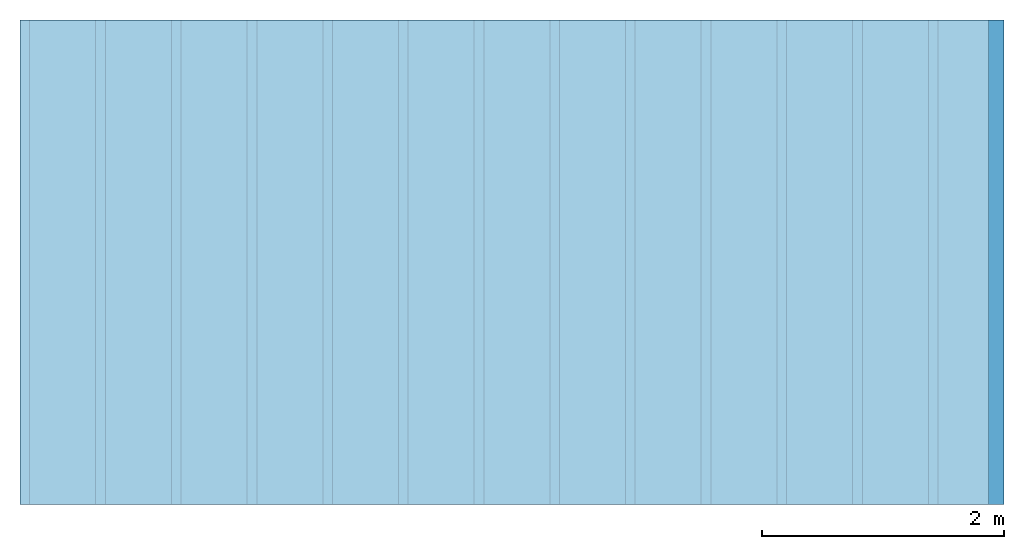
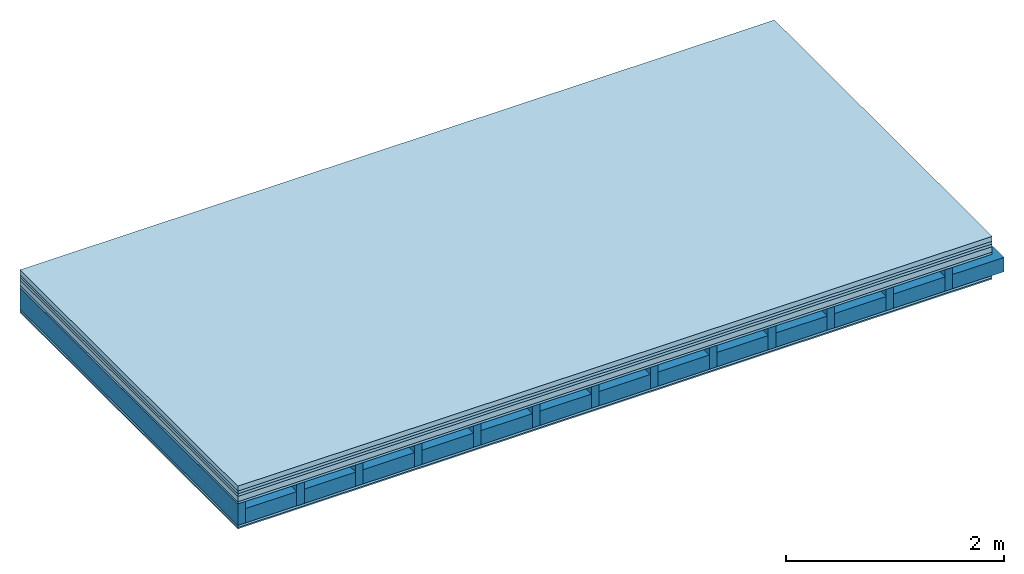
# One storey: 7 plates, 2 members, 1 element without a shape of its own.
"""IFC4 building model written with IfcOpenShell, lengths in metres."""

from ifc_helpers import new_model, si_unit, derived_unit, direction, frame, frame_2d, origin, origin_with_axes, place, context, project, spatial, rectangle, extrude, material, layer, layer_set, type_object, element, aggregate, save


model = new_model("IFC4")

# Units and contexts
plan_context = context("Plan", 3, precision=1e-05, world=origin(), true_north=direction((0.0, 1.0)))
model_context = context("Model", 3, precision=1e-05, world=origin(), true_north=direction((0.0, 1.0)))
ifc_project = project(units=[si_unit("LENGTHUNIT", "METRE"), derived_unit("SOUNDPRESSUREUNIT", [(si_unit("PRESSUREUNIT", "PASCAL", prefix="MICRO"), 0)]), si_unit("ENERGYUNIT", "JOULE", prefix="MEGA"), si_unit("MASSUNIT", "GRAM", prefix="KILO"), derived_unit("THERMALTRANSMITTANCEUNIT", [(si_unit("POWERUNIT", "WATT"), 1), (si_unit("AREAUNIT", "SQUARE_METRE"), -1), (si_unit("THERMODYNAMICTEMPERATUREUNIT", "KELVIN"), -1)]), derived_unit("AREADENSITYUNIT", [(si_unit("MASSUNIT", "GRAM", prefix="KILO"), 1), (si_unit("AREAUNIT", "SQUARE_METRE"), -1)]), derived_unit("USERDEFINED", [(si_unit("ENERGYUNIT", "JOULE", prefix="MEGA"), 1), (si_unit("AREAUNIT", "SQUARE_METRE"), -1)])], contexts=[plan_context, model_context])

# Site, building, storey
site = spatial("IfcSite", under=ifc_project)
building_placement = place(None, origin())
building = spatial("IfcBuilding", under=site, at=building_placement)
storey_placement = place(building_placement, origin())
storey = spatial("IfcBuildingStorey", under=building, at=storey_placement)

# Slab, members, plates
ifc_material_1 = material(Category="04.005")
ifc_layer_1 = layer(ifc_material_1, 0.055, Name="On-material")
ifc_material_2 = material()
ifc_layer_2 = layer(ifc_material_2, 0.03, Name="Impact sound insulation")
ifc_material_3 = material()
ifc_layer_3 = layer(ifc_material_3, 0.03, Name="Additional insulation")
ifc_material_4 = material(Category="03.011")
ifc_layer_4 = layer(ifc_material_4, 0.06, Name="on Supporting structure")
ifc_material_5 = material(Category="07.001")
ifc_layer_5 = layer(ifc_material_5, 0.025, Name="Sub-floor")
ifc_material_6 = material(Name="Rigid, of the art")
ifc_layer_6 = layer(ifc_material_6, 0.0, Name="Bond")
ifc_layer_7 = layer(None, 0.24, Name="Supporting structure")
ifc_layer_8 = layer(ifc_material_6, 0.0, Name="Bond")
ifc_layer_9 = layer(ifc_material_5, 0.025, Name="Lower layer 1")
ifc_material_7 = material(Category="03.007")
ifc_layer_10 = layer(ifc_material_7, 0.015, Name="Lower 2nd layer")
ifc_layer_set = layer_set([ifc_layer_1, ifc_layer_2, ifc_layer_3, ifc_layer_4, ifc_layer_5, ifc_layer_6, ifc_layer_7, ifc_layer_8, ifc_layer_9, ifc_layer_10])
slab_type = type_object("IfcSlabType", Name="A0445", PredefinedType="NOTDEFINED", material=ifc_layer_set)
slab_placement = place(None, frame((0.0, 0.0, 0.0), z_axis=(0.0, 0.0, -1.0), x_axis=(1.0, 0.0, 0.0)))
slab = element("IfcSlab", 1, at=slab_placement, inside=storey, type_object=slab_type, material=ifc_layer_set, Name="Slab #1")
ifc_material_8 = material()
member_1_placement = place(slab_placement, origin())
member_1 = element("IfcMember", 2, at=member_1_placement, material=ifc_material_8, Name="Supporting structure", context=plan_context, shape_type="SweptSolid", body=[
    extrude(rectangle(XDim=0.08, YDim=0.24, at=frame_2d((0.04, 0.12), x_axis=(1.0, 0.0))), frame((0.0, 4.0, 0.2), z_axis=(0.0, -1.0, 0.0), x_axis=(1.0, 0.0, 0.0)), (0.0, 0.0, 1.0), 4.0),
    extrude(rectangle(XDim=0.08, YDim=0.24, at=frame_2d((0.04, 0.12), x_axis=(1.0, 0.0))), frame((0.625, 4.0, 0.2), z_axis=(0.0, -1.0, 0.0), x_axis=(1.0, 0.0, 0.0)), (0.0, 0.0, 1.0), 4.0),
    extrude(rectangle(XDim=0.08, YDim=0.24, at=frame_2d((0.04, 0.12), x_axis=(1.0, 0.0))), frame((1.25, 4.0, 0.2), z_axis=(0.0, -1.0, 0.0), x_axis=(1.0, 0.0, 0.0)), (0.0, 0.0, 1.0), 4.0),
    extrude(rectangle(XDim=0.08, YDim=0.24, at=frame_2d((0.04, 0.12), x_axis=(1.0, 0.0))), frame((1.875, 4.0, 0.2), z_axis=(0.0, -1.0, 0.0), x_axis=(1.0, 0.0, 0.0)), (0.0, 0.0, 1.0), 4.0),
    extrude(rectangle(XDim=0.08, YDim=0.24, at=frame_2d((0.04, 0.12), x_axis=(1.0, 0.0))), frame((2.5, 4.0, 0.2), z_axis=(0.0, -1.0, 0.0), x_axis=(1.0, 0.0, 0.0)), (0.0, 0.0, 1.0), 4.0),
    extrude(rectangle(XDim=0.08, YDim=0.24, at=frame_2d((0.04, 0.12), x_axis=(1.0, 0.0))), frame((3.125, 4.0, 0.2), z_axis=(0.0, -1.0, 0.0), x_axis=(1.0, 0.0, 0.0)), (0.0, 0.0, 1.0), 4.0),
    extrude(rectangle(XDim=0.08, YDim=0.24, at=frame_2d((0.04, 0.12), x_axis=(1.0, 0.0))), frame((3.75, 4.0, 0.2), z_axis=(0.0, -1.0, 0.0), x_axis=(1.0, 0.0, 0.0)), (0.0, 0.0, 1.0), 4.0),
    extrude(rectangle(XDim=0.08, YDim=0.24, at=frame_2d((0.04, 0.12), x_axis=(1.0, 0.0))), frame((4.375, 4.0, 0.2), z_axis=(0.0, -1.0, 0.0), x_axis=(1.0, 0.0, 0.0)), (0.0, 0.0, 1.0), 4.0),
    extrude(rectangle(XDim=0.08, YDim=0.24, at=frame_2d((0.04, 0.12), x_axis=(1.0, 0.0))), frame((5.0, 4.0, 0.2), z_axis=(0.0, -1.0, 0.0), x_axis=(1.0, 0.0, 0.0)), (0.0, 0.0, 1.0), 4.0),
    extrude(rectangle(XDim=0.08, YDim=0.24, at=frame_2d((0.04, 0.12), x_axis=(1.0, 0.0))), frame((5.625, 4.0, 0.2), z_axis=(0.0, -1.0, 0.0), x_axis=(1.0, 0.0, 0.0)), (0.0, 0.0, 1.0), 4.0),
    extrude(rectangle(XDim=0.08, YDim=0.24, at=frame_2d((0.04, 0.12), x_axis=(1.0, 0.0))), frame((6.25, 4.0, 0.2), z_axis=(0.0, -1.0, 0.0), x_axis=(1.0, 0.0, 0.0)), (0.0, 0.0, 1.0), 4.0),
    extrude(rectangle(XDim=0.08, YDim=0.24, at=frame_2d((0.04, 0.12), x_axis=(1.0, 0.0))), frame((6.875, 4.0, 0.2), z_axis=(0.0, -1.0, 0.0), x_axis=(1.0, 0.0, 0.0)), (0.0, 0.0, 1.0), 4.0),
    extrude(rectangle(XDim=0.08, YDim=0.24, at=frame_2d((0.04, 0.12), x_axis=(1.0, 0.0))), frame((7.5, 4.0, 0.2), z_axis=(0.0, -1.0, 0.0), x_axis=(1.0, 0.0, 0.0)), (0.0, 0.0, 1.0), 4.0),
])
ifc_material_9 = material()
member_2_placement = place(slab_placement, origin())
member_2 = element("IfcMember", 3, at=member_2_placement, material=ifc_material_9, Name="Cavity", context=plan_context, shape_type="SweptSolid", body=[
    extrude(rectangle(XDim=0.545, YDim=0.16, at=frame_2d((0.2725, 0.08), x_axis=(1.0, 0.0))), frame((0.08, 4.0, 0.28), z_axis=(0.0, -1.0, 0.0), x_axis=(1.0, 0.0, 0.0)), (0.0, 0.0, 1.0), 4.0),
    extrude(rectangle(XDim=0.545, YDim=0.16, at=frame_2d((0.2725, 0.08), x_axis=(1.0, 0.0))), frame((0.705, 4.0, 0.28), z_axis=(0.0, -1.0, 0.0), x_axis=(1.0, 0.0, 0.0)), (0.0, 0.0, 1.0), 4.0),
    extrude(rectangle(XDim=0.545, YDim=0.16, at=frame_2d((0.2725, 0.08), x_axis=(1.0, 0.0))), frame((1.33, 4.0, 0.28), z_axis=(0.0, -1.0, 0.0), x_axis=(1.0, 0.0, 0.0)), (0.0, 0.0, 1.0), 4.0),
    extrude(rectangle(XDim=0.545, YDim=0.16, at=frame_2d((0.2725, 0.08), x_axis=(1.0, 0.0))), frame((1.955, 4.0, 0.28), z_axis=(0.0, -1.0, 0.0), x_axis=(1.0, 0.0, 0.0)), (0.0, 0.0, 1.0), 4.0),
    extrude(rectangle(XDim=0.545, YDim=0.16, at=frame_2d((0.2725, 0.08), x_axis=(1.0, 0.0))), frame((2.58, 4.0, 0.28), z_axis=(0.0, -1.0, 0.0), x_axis=(1.0, 0.0, 0.0)), (0.0, 0.0, 1.0), 4.0),
    extrude(rectangle(XDim=0.545, YDim=0.16, at=frame_2d((0.2725, 0.08), x_axis=(1.0, 0.0))), frame((3.205, 4.0, 0.28), z_axis=(0.0, -1.0, 0.0), x_axis=(1.0, 0.0, 0.0)), (0.0, 0.0, 1.0), 4.0),
    extrude(rectangle(XDim=0.545, YDim=0.16, at=frame_2d((0.2725, 0.08), x_axis=(1.0, 0.0))), frame((3.83, 4.0, 0.28), z_axis=(0.0, -1.0, 0.0), x_axis=(1.0, 0.0, 0.0)), (0.0, 0.0, 1.0), 4.0),
    extrude(rectangle(XDim=0.545, YDim=0.16, at=frame_2d((0.2725, 0.08), x_axis=(1.0, 0.0))), frame((4.455, 4.0, 0.28), z_axis=(0.0, -1.0, 0.0), x_axis=(1.0, 0.0, 0.0)), (0.0, 0.0, 1.0), 4.0),
    extrude(rectangle(XDim=0.545, YDim=0.16, at=frame_2d((0.2725, 0.08), x_axis=(1.0, 0.0))), frame((5.08, 4.0, 0.28), z_axis=(0.0, -1.0, 0.0), x_axis=(1.0, 0.0, 0.0)), (0.0, 0.0, 1.0), 4.0),
    extrude(rectangle(XDim=0.545, YDim=0.16, at=frame_2d((0.2725, 0.08), x_axis=(1.0, 0.0))), frame((5.705, 4.0, 0.28), z_axis=(0.0, -1.0, 0.0), x_axis=(1.0, 0.0, 0.0)), (0.0, 0.0, 1.0), 4.0),
    extrude(rectangle(XDim=0.545, YDim=0.16, at=frame_2d((0.2725, 0.08), x_axis=(1.0, 0.0))), frame((6.33, 4.0, 0.28), z_axis=(0.0, -1.0, 0.0), x_axis=(1.0, 0.0, 0.0)), (0.0, 0.0, 1.0), 4.0),
    extrude(rectangle(XDim=0.545, YDim=0.16, at=frame_2d((0.2725, 0.08), x_axis=(1.0, 0.0))), frame((6.955, 4.0, 0.28), z_axis=(0.0, -1.0, 0.0), x_axis=(1.0, 0.0, 0.0)), (0.0, 0.0, 1.0), 4.0),
    extrude(rectangle(XDim=0.545, YDim=0.16, at=frame_2d((0.2725, 0.08), x_axis=(1.0, 0.0))), frame((7.58, 4.0, 0.28), z_axis=(0.0, -1.0, 0.0), x_axis=(1.0, 0.0, 0.0)), (0.0, 0.0, 1.0), 4.0),
])
plate_1_placement = place(slab_placement, origin())
plate_1 = element("IfcPlate", 4, at=plate_1_placement, material=ifc_material_1, Name="On-material", context=plan_context, shape_type="SweptSolid", body=[
    extrude(rectangle(XDim=8.0, YDim=4.0, at=frame_2d((4.0, 2.0), x_axis=(1.0, 0.0))), origin_with_axes(), (0.0, 0.0, 1.0), 0.055),
])
plate_2_placement = place(slab_placement, origin())
plate_2 = element("IfcPlate", 5, at=plate_2_placement, material=ifc_material_2, Name="Impact sound insulation", context=plan_context, shape_type="SweptSolid", body=[
    extrude(rectangle(XDim=8.0, YDim=4.0, at=frame_2d((4.0, 2.0), x_axis=(1.0, 0.0))), frame((0.0, 0.0, 0.055), z_axis=(0.0, 0.0, 1.0), x_axis=(1.0, 0.0, 0.0)), (0.0, 0.0, 1.0), 0.03),
])
plate_3_placement = place(slab_placement, origin())
plate_3 = element("IfcPlate", 6, at=plate_3_placement, material=ifc_material_3, Name="Additional insulation", context=plan_context, shape_type="SweptSolid", body=[
    extrude(rectangle(XDim=8.0, YDim=4.0, at=frame_2d((4.0, 2.0), x_axis=(1.0, 0.0))), frame((0.0, 0.0, 0.085), z_axis=(0.0, 0.0, 1.0), x_axis=(1.0, 0.0, 0.0)), (0.0, 0.0, 1.0), 0.03),
])
plate_4_placement = place(slab_placement, origin())
plate_4 = element("IfcPlate", 7, at=plate_4_placement, material=ifc_material_4, Name="on Supporting structure", context=plan_context, shape_type="SweptSolid", body=[
    extrude(rectangle(XDim=8.0, YDim=4.0, at=frame_2d((4.0, 2.0), x_axis=(1.0, 0.0))), frame((0.0, 0.0, 0.115), z_axis=(0.0, 0.0, 1.0), x_axis=(1.0, 0.0, 0.0)), (0.0, 0.0, 1.0), 0.06),
])
plate_5_placement = place(slab_placement, origin())
plate_5 = element("IfcPlate", 8, at=plate_5_placement, material=ifc_material_5, Name="Sub-floor", context=plan_context, shape_type="SweptSolid", body=[
    extrude(rectangle(XDim=8.0, YDim=4.0, at=frame_2d((4.0, 2.0), x_axis=(1.0, 0.0))), frame((0.0, 0.0, 0.175), z_axis=(0.0, 0.0, 1.0), x_axis=(1.0, 0.0, 0.0)), (0.0, 0.0, 1.0), 0.025),
])
plate_6_placement = place(slab_placement, origin())
plate_6 = element("IfcPlate", 9, at=plate_6_placement, material=ifc_material_5, Name="Lower layer 1", context=plan_context, shape_type="SweptSolid", body=[
    extrude(rectangle(XDim=8.0, YDim=4.0, at=frame_2d((4.0, 2.0), x_axis=(1.0, 0.0))), frame((0.0, 0.0, 0.44), z_axis=(0.0, 0.0, 1.0), x_axis=(1.0, 0.0, 0.0)), (0.0, 0.0, 1.0), 0.025),
])
plate_7_placement = place(slab_placement, origin())
plate_7 = element("IfcPlate", 10, at=plate_7_placement, material=ifc_material_7, Name="Lower 2nd layer", context=plan_context, shape_type="SweptSolid", body=[
    extrude(rectangle(XDim=8.0, YDim=4.0, at=frame_2d((4.0, 2.0), x_axis=(1.0, 0.0))), frame((0.0, 0.0, 0.465), z_axis=(0.0, 0.0, 1.0), x_axis=(1.0, 0.0, 0.0)), (0.0, 0.0, 1.0), 0.015),
])
aggregate(slab, [plate_1, plate_2, plate_3, plate_4, plate_5, member_1, member_2, plate_6, plate_7])

save(model, "model.ifc")
